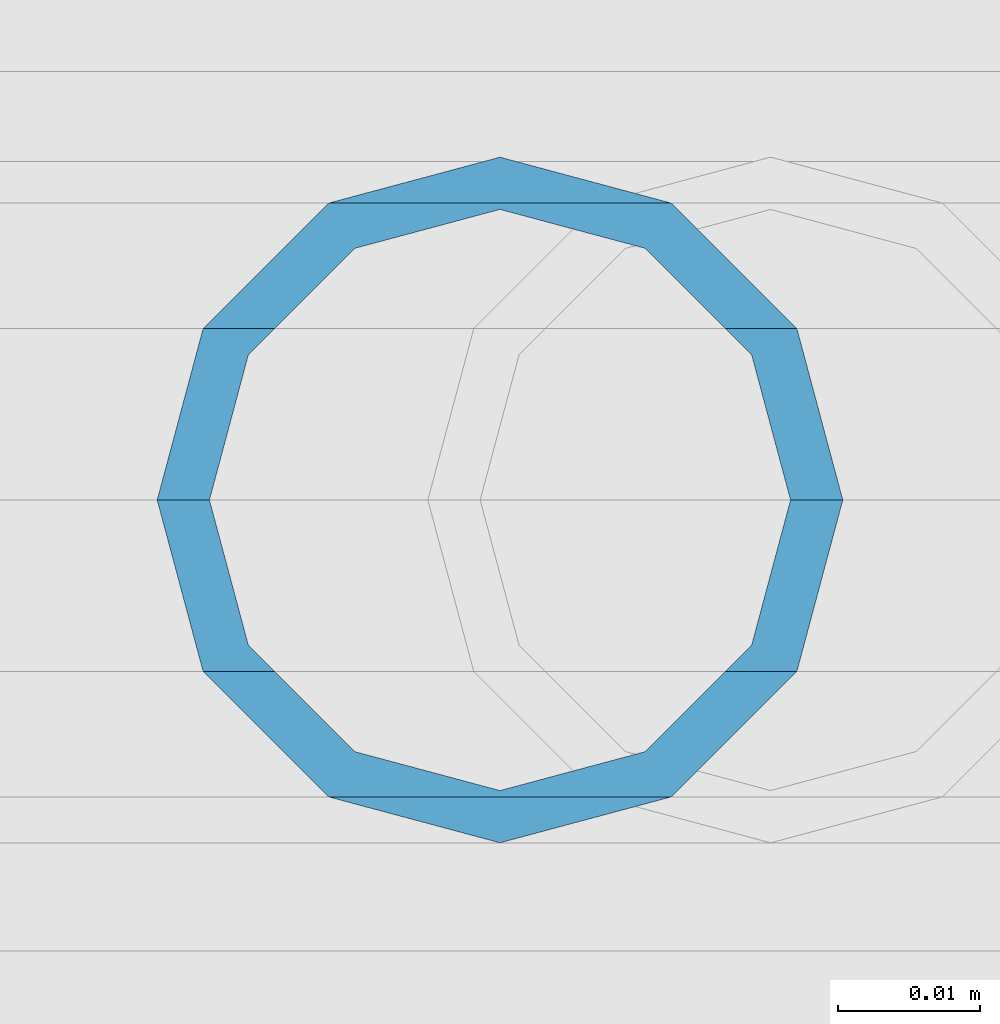
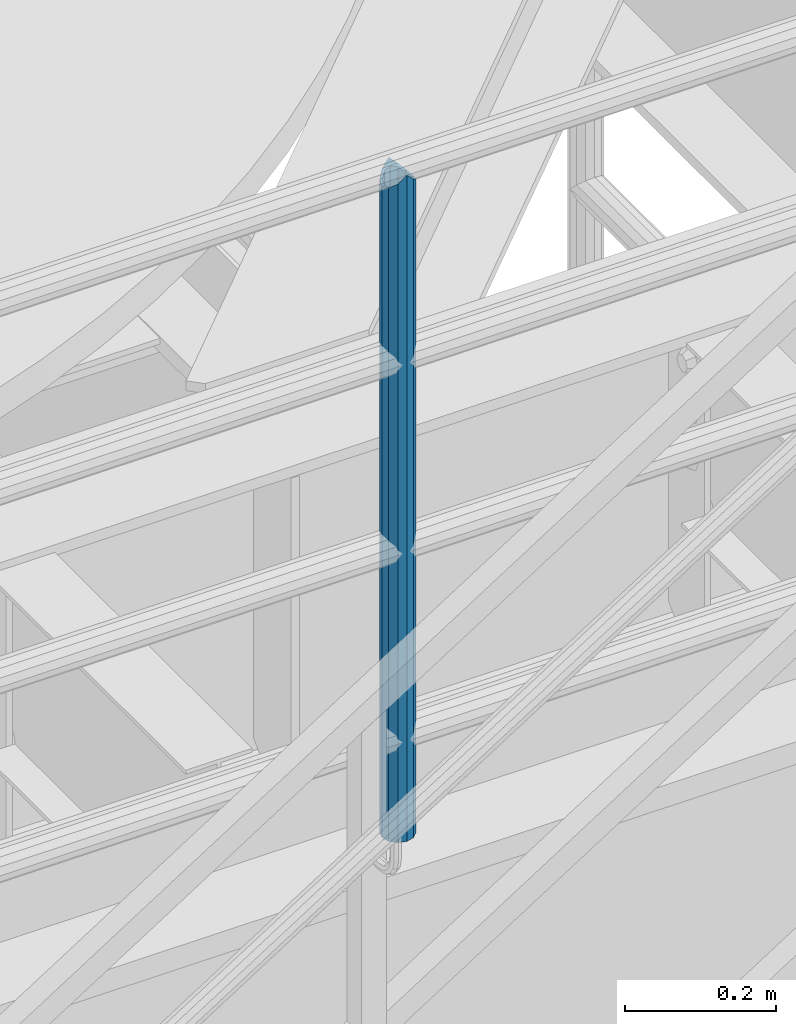
# One storey, part 634 of 1876: 1 column, 1 element without a shape of its own.
"""IFC2X3 building model written with IfcOpenShell, lengths in millimetres."""

from ifc_helpers import new_model, si_unit, frame, origin_with_axes, place, context, subcontext, project, spatial, faceted_brep, material, type_object, element, aggregate, save


model = new_model("IFC2X3")

# Units and contexts
model_context = context("Model", 3, precision=1e-05, world=origin_with_axes())
body_context = subcontext(model_context, "Body", "Model", "MODEL_VIEW")
ifc_project = project(units=[si_unit("LENGTHUNIT", "METRE", prefix="MILLI"), si_unit("AREAUNIT", "SQUARE_METRE"), si_unit("VOLUMEUNIT", "CUBIC_METRE"), si_unit("MASSUNIT", "GRAM", prefix="KILO"), si_unit("TIMEUNIT", "SECOND"), si_unit("PLANEANGLEUNIT", "RADIAN"), si_unit("SOLIDANGLEUNIT", "STERADIAN"), si_unit("THERMODYNAMICTEMPERATUREUNIT", "DEGREE_CELSIUS"), si_unit("LUMINOUSINTENSITYUNIT", "LUMEN")], contexts=[model_context])

# Site, building, storey
site_placement = place(None, origin_with_axes())
site = spatial("IfcSite", under=ifc_project, at=site_placement, CompositionType="ELEMENT")
building_placement = place(site_placement, origin_with_axes())
building = spatial("IfcBuilding", under=site, at=building_placement, Name="Undefined", CompositionType="ELEMENT")
storey_placement = place(building_placement, origin_with_axes())
storey = spatial("IfcBuildingStorey", under=building, at=storey_placement, Name="Undefined", CompositionType="ELEMENT", Elevation=0.0)

# Assembly, column
assembly_placement = place(storey_placement, origin_with_axes())
assembly = element("IfcElementAssembly", 1, at=assembly_placement, inside=storey, Name="RAIL", AssemblyPlace="NOTDEFINED", PredefinedType="RIGID_FRAME")
ifc_material = material()
column_type = type_object("IfcColumnType", Name="PIPE1-1/2SCH40", PredefinedType="NOTDEFINED")
column_placement = place(assembly_placement, frame((5048.24999996468, -4654.55000114554, 8153.4), z_axis=(0.0, 1.0, 0.0), x_axis=(0.0, 0.0, 1.0)))
column = element("IfcColumn", 2, at=column_placement, type_object=column_type, material=ifc_material, Name="POST", ObjectType="PIPE1-1/2SCH40", context=body_context, shape_type="Brep", body=[
    faceted_brep([(1076.325, 0.0, -24.1300000000001), (1064.26, 12.065, -20.8971929933186), (1064.26, -12.0650000000001, -20.8971929933186), (1054.93437856882, 17.7076214311801, 10.2235000000001), (1052.195, 20.4470000000001, 0.0), (1052.195, 24.13, 0.0), (1055.42780700668, 20.8971929933185, 12.0649999999996), (1055.42780700668, 15.8661214311869, 12.0649999999932), (1055.42780700668, 15.8661214311742, -12.065000000006), (1055.42780700668, 20.8971929933185, -12.0649999999996), (1054.93437856882, 17.7076214311801, -10.2235000000001), (1061.07042843786, 10.2235000000001, -17.7076214311801), (1063.80980700668, 0.0, -20.4470000000001), (1061.07042843786, -10.2235000000001, -17.7076214311801), (1055.42780700668, -15.8661214311742, -12.065000000006), (1055.42780700668, -20.8971929933184, -12.0649999999996), (1054.93437856882, -17.7076214311801, -10.2235000000001), (1052.195, -20.4470000000001, 0.0), (1052.195, -24.1300000000001, 0.0), (1054.93437856882, -17.7076214311801, 10.2235000000001), (1055.42780700668, -15.8661214311869, 12.0649999999932), (1055.42780700668, -20.8971929933184, 12.0649999999996), (1076.325, 0.0, 24.1300000000001), (1064.26, -12.0650000000001, 20.8971929933186), (1064.26, 12.065, 20.8971929933186), (1061.07042843787, -10.2235000000001, 17.7076214311801), (1063.80980700669, 0.0, 20.4470000000001), (1061.07042843787, 10.2235000000001, 17.7076214311801), (0.0, -20.8971929933184, -12.0649999999996), (0.0, -12.0650000000001, -20.8971929933186), (-1.45519152283669e-11, 0.0, -24.130000000001), (0.0, 12.0650000000001, -20.8971929933186), (0.0, 20.8971929933184, -12.0649999999996), (0.0, 24.1299999999992, 0.0), (0.0, 20.8971929933184, 12.0649999999996), (0.0, 12.0650000000001, 20.8971929933186), (-1.45519152283669e-11, 0.0, 24.130000000001), (0.0, -20.8971929933184, 12.0649999999996), (0.0, -24.1299999999992, 0.0), (0.0, -12.0650000000001, 20.8971929933186), (0.0, -17.7076214311803, -10.2235000000001), (0.0, -10.2235000000001, -17.7076214311801), (-1.45519152283669e-11, 0.0, -20.4470000000001), (0.0, 10.2235000000001, -17.7076214311801), (0.0, 17.7076214311803, -10.2235000000001), (0.0, 20.4469999999999, 0.0), (0.0, 17.7076214311803, 10.2235000000001), (0.0, 10.2235000000001, 17.7076214311801), (-1.45519152283669e-11, 0.0, 20.4470000000001), (0.0, -10.2235000000001, 17.7076214311801), (0.0, -17.7076214311803, 10.2235000000001), (0.0, -20.4469999999999, 0.0)], [[[0, 1, 2]], [[3, 4, 5, 6, 7]], [[8, 9, 5, 4, 10]], [[2, 1, 9, 8, 11, 12, 13, 14, 15]], [[15, 14, 16, 17, 18]], [[18, 17, 19, 20, 21]], [[22, 23, 24]], [[21, 20, 25, 26, 27, 7, 6, 24, 23]], [[28, 29, 2, 15]], [[29, 30, 0, 2]], [[30, 31, 1, 0]], [[31, 32, 9, 1]], [[32, 33, 5, 9]], [[33, 34, 6, 5]], [[34, 35, 24, 6]], [[35, 36, 22, 24]], [[37, 38, 18, 21]], [[39, 37, 21, 23]], [[36, 39, 23, 22]], [[38, 28, 15, 18]], [[37, 39, 36, 35, 34, 33, 32, 31, 30, 29, 28, 38], [40, 41, 42, 43, 44, 45, 46, 47, 48, 49, 50, 51]], [[49, 48, 26, 25]], [[19, 50, 49, 25, 20]], [[51, 50, 19, 17]], [[40, 51, 17, 16]], [[41, 40, 16, 14, 13]], [[42, 41, 13, 12]], [[43, 42, 12, 11]], [[10, 44, 43, 11, 8]], [[45, 44, 10, 4]], [[46, 45, 4, 3]], [[47, 46, 3, 7, 27]], [[48, 47, 27, 26]]]),
])
aggregate(assembly, [column])

save(model, "model.ifc")
